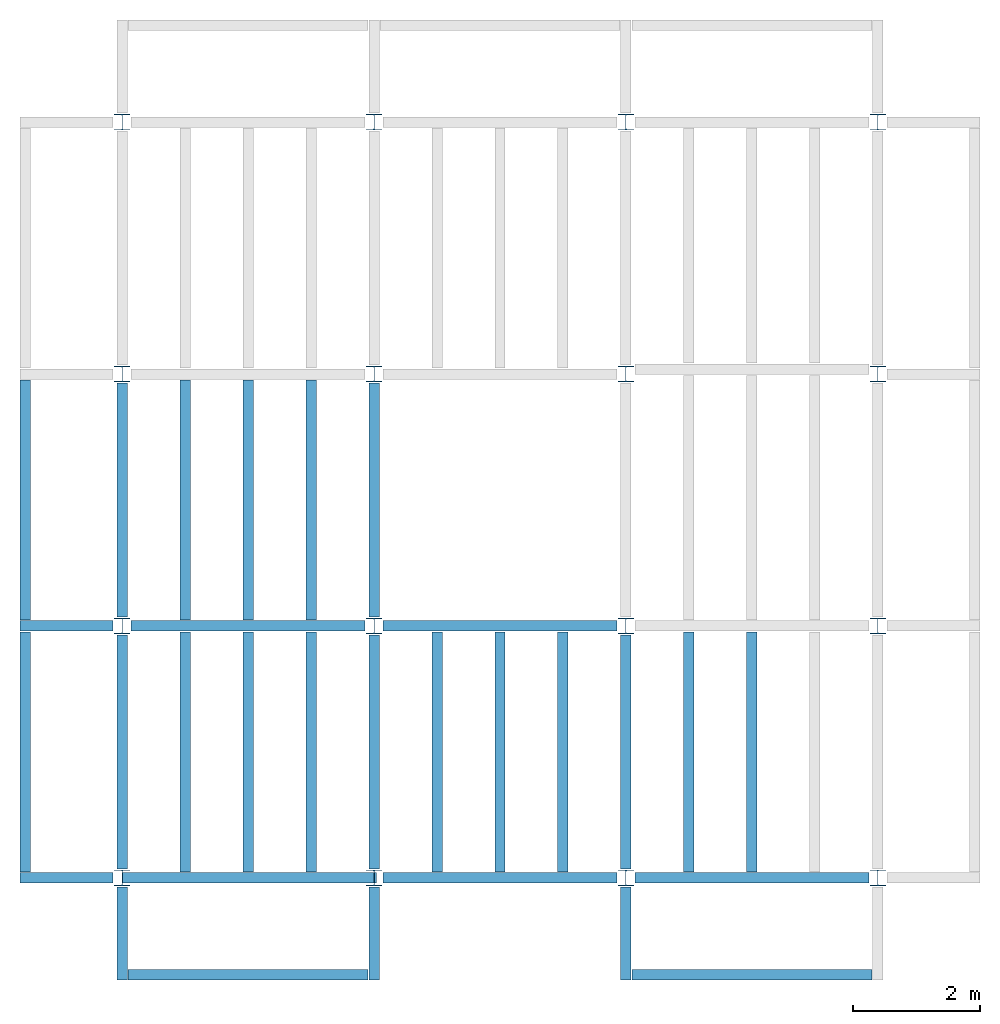
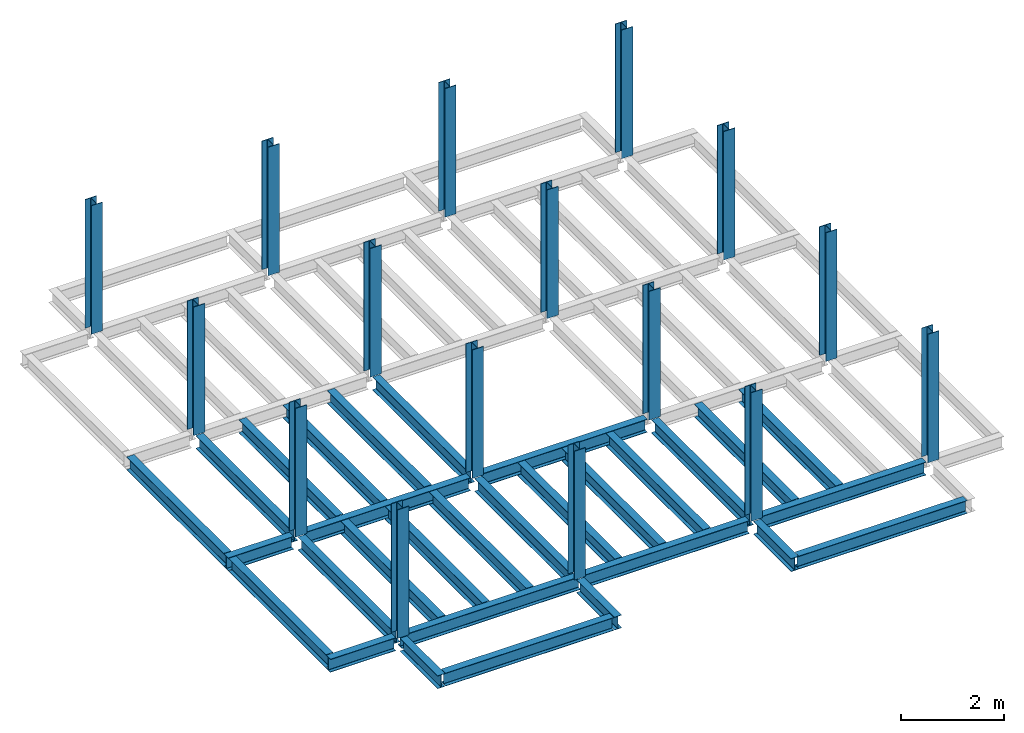
# One storey, part 1 of 3: 30 beams, 16 columns, 4 elements without a shape of their own.
"""IFC4 building model written with IfcOpenShell, lengths in feet."""

from ifc_helpers import new_model, entity, si_unit, converted_unit, derived_unit, direction, frame, origin, origin_2d, place, context, subcontext, project, spatial, line, arc, indexed_curve, i_section, outline, extrude, source, transform, mapped, material, type_object, type_shapes, element, aggregate, save


model = new_model("IFC4")

# Units and contexts
model_context = context("Model", 3, precision=0.0001, world=origin(), true_north=direction((6.123233995736766e-17, 1.0)))
plan_context = context("Plan", 3, precision=0.0001, world=origin(), true_north=direction((6.123233995736766e-17, 1.0)))
body_context = subcontext(model_context, "Body", "Model", "MODEL_VIEW")
ifc_project = project(units=[converted_unit("LENGTHUNIT", "FOOT", entity("IfcLengthMeasure", 0.3048), si_unit("LENGTHUNIT", "METRE"), dimensions=[1, 0, 0, 0, 0, 0, 0]), converted_unit("AREAUNIT", "SQUARE FOOT", entity("IfcAreaMeasure", 0.09290304), si_unit("AREAUNIT", "SQUARE_METRE"), dimensions=[2, 0, 0, 0, 0, 0, 0]), converted_unit("PLANEANGLEUNIT", "DEGREE", entity("IfcPlaneAngleMeasure", 0.017453292519943278), si_unit("PLANEANGLEUNIT", "RADIAN"), dimensions=[0, 0, 0, 0, 0, 0, 0]), converted_unit("VOLUMEUNIT", "CUBIC FOOT", entity("IfcVolumeMeasure", 0.028316846592000004), si_unit("VOLUMEUNIT", "CUBIC_METRE"), dimensions=[3, 0, 0, 0, 0, 0, 0]), si_unit("PRESSUREUNIT", "PASCAL"), derived_unit("MASSDENSITYUNIT", [(si_unit("MASSUNIT", "GRAM", prefix="KILO"), 1), (si_unit("LENGTHUNIT", "METRE"), -3)]), derived_unit("VAPORPERMEABILITYUNIT", [(si_unit("LENGTHUNIT", "METRE"), -1), (si_unit("TIMEUNIT", "SECOND"), 1)]), derived_unit("USERDEFINED", [(si_unit("MASSUNIT", "GRAM", prefix="KILO"), 1), (si_unit("LENGTHUNIT", "METRE"), 3), (si_unit("TIMEUNIT", "SECOND"), -3), (si_unit("ELECTRICCURRENTUNIT", "AMPERE"), -2)]), derived_unit("MODULUSOFELASTICITYUNIT", [(si_unit("MASSUNIT", "GRAM", prefix="KILO"), 1), (si_unit("LENGTHUNIT", "METRE"), -1), (si_unit("TIMEUNIT", "SECOND"), -2)]), derived_unit("THERMALEXPANSIONCOEFFICIENTUNIT", [(si_unit("THERMODYNAMICTEMPERATUREUNIT", "KELVIN"), -1)]), derived_unit("SPECIFICHEATCAPACITYUNIT", [(si_unit("TIMEUNIT", "SECOND"), -2), (si_unit("THERMODYNAMICTEMPERATUREUNIT", "KELVIN"), -1), (si_unit("LENGTHUNIT", "METRE"), 2)]), derived_unit("THERMALCONDUCTANCEUNIT", [(si_unit("MASSUNIT", "GRAM", prefix="KILO"), 1), (si_unit("TIMEUNIT", "SECOND"), -3), (si_unit("THERMODYNAMICTEMPERATUREUNIT", "KELVIN"), -1), (si_unit("LENGTHUNIT", "METRE"), 1)])], contexts=[model_context, plan_context])

# Site, building, storey
site_placement = place(None, origin())
site = spatial("IfcSite", under=ifc_project, at=site_placement, CompositionType="ELEMENT")
building_placement = place(site_placement, origin())
building = spatial("IfcBuilding", under=site, at=building_placement, CompositionType="ELEMENT")
storey_placement = place(building_placement, frame((0.0, 0.0, 19.875)))
storey = spatial("IfcBuildingStorey", under=building, at=storey_placement, Name="STR 03", CompositionType="ELEMENT", Elevation=19.875)

# Columns
ifc_material = material(Name="Steel ASTM A992", Category="Metal")
column_type = type_object("IfcColumnType", Name="W10X49", PredefinedType="COLUMN", material=ifc_material)
shared_shape_1 = source(origin(), body_context, "Body", "SweptSolid", [
    extrude(outline(indexed_curve([(-0.41666666666666663, -0.4166666666666676), (0.41666666666666663, -0.4166666666666676), (0.41666666666666663, -0.3699999999999996), (0.055833333333333846, -0.3699999999999996), (0.02637055078389421, -0.35779611588277277), (0.014166666666666636, -0.32833333333333287), (0.01416666666666665, 0.32833333333333303), (0.026370550783893467, 0.3577961158827727), (0.05583333333333332, 0.3700000000000003), (0.41666666666666663, 0.3700000000000003), (0.41666666666666663, 0.4166666666666656), (-0.41666666666666663, 0.4166666666666656), (-0.41666666666666663, 0.3700000000000003), (-0.05583333333333365, 0.3700000000000003), (-0.02637055078389416, 0.3577961158827734), (-0.014166666666666685, 0.32833333333333387), (-0.014166666666666685, -0.32833333333333264), (-0.026370550783893578, -0.3577961158827721), (-0.055833333333333374, -0.3699999999999996), (-0.41666666666666663, -0.3699999999999996)], segments=[line(1, 2, 3, 4), arc(4, 5, 6), line(6, 7), arc(7, 8, 9), line(9, 10, 11, 12, 13, 14), arc(14, 15, 16), line(16, 17), arc(17, 18, 19), line(19, 20, 1)], self_intersect=False)), frame((0.0, 0.0, 19.875), z_axis=(0.0, 0.0, 1.0), x_axis=(-1.0, 0.0, 0.0)), (0.0, 0.0, 1.0), 10.0),
])
type_shapes(column_type, [shared_shape_1])
for number, where, z_axis, x_axis, name in (
    (1, (13.0, 0.0, -19.875), (0.0, 0.0, 1.0), (-1.0, 0.0, 0.0), "W10X49"),
    (2, (13.0, 13.0, -19.875), (0.0, 0.0, 1.0), (-1.0, 0.0, 0.0), "W10X49"),
    (3, (13.0, 26.0, -19.875), (0.0, 0.0, 1.0), (-1.0, 0.0, 0.0), "W10X49"),
    (4, (13.0, 39.0, -19.875), (0.0, 0.0, 1.0), (-1.0, 0.0, 0.0), "W10X49"),
    (5, (0.0, 0.0, -19.875), (0.0, 0.0, 1.0), (-1.0, 0.0, 0.0), "W10X49"),
    (6, (0.0, 13.0, -19.875), (0.0, 0.0, 1.0), (-1.0, 0.0, 0.0), "W10X49"),
    (7, (0.0, 26.0, -19.875), (0.0, 0.0, 1.0), (-1.0, 0.0, 0.0), "W10X49"),
    (8, (0.0, 39.0, -19.875), (0.0, 0.0, 1.0), (-1.0, 0.0, 0.0), "W10X49"),
    (9, (26.0, 0.0, -19.875), (0.0, 0.0, 1.0), (-1.0, 0.0, 0.0), "W10X49"),
    (10, (26.0, 13.0, -19.875), (0.0, 0.0, 1.0), (-1.0, 0.0, 0.0), "W10X49"),
    (11, (26.0, 26.0, -19.875), (0.0, 0.0, 1.0), (-1.0, 0.0, 0.0), "W10X49"),
    (12, (26.0, 39.0, -19.875), (0.0, 0.0, 1.0), (-1.0, 0.0, 0.0), "W10X49"),
    (13, (39.0, 0.0, -19.875), (0.0, 0.0, 1.0), (-1.0, 0.0, 0.0), "W10X49"),
    (14, (39.0, 13.0, -19.875), (0.0, 0.0, 1.0), (-1.0, 0.0, 0.0), "W10X49"),
    (15, (39.0, 26.0, -19.875), (0.0, 0.0, 1.0), (-1.0, 0.0, 0.0), "W10X49"),
    (16, (39.0, 39.0, -19.875), (0.0, 0.0, 1.0), (-1.0, 0.0, 0.0), "W10X49"),
):
    element("IfcColumn", number, at=place(storey_placement, frame(where, z_axis=z_axis, x_axis=x_axis)), inside=storey, type_object=column_type, material=ifc_material, Name=name, ObjectType="W Shapes-Column:W10X49", PredefinedType="COLUMN", context=body_context, shape_type="MappedRepresentation", body=[
        mapped(shared_shape_1, transform((0.0, 0.0, 0.0), scale=1.0)),
    ])

# Beams
beam_type_1 = type_object("IfcBeamType", Name="W12X26", PredefinedType="JOIST", material=ifc_material)
shared_shape_2 = source(origin(), body_context, "Body", "SweptSolid", [
    extrude(outline(indexed_curve([(-0.27041666666666714, -0.47666666666666574), (-0.27041666666666714, -0.5083333333333351), (0.2704166666666669, -0.5083333333333351), (0.2704166666666669, -0.47666666666666574), (0.03458333333333309, -0.47666666666666574), (0.016905663803669493, -0.46934433619632937), (0.009583333333333202, -0.4516666666666659), (0.0095833333333332, 0.45166666666666705), (0.01690566380366948, 0.4693443361963307), (0.03458333333333325, 0.4766666666666671), (0.2704166666666669, 0.4766666666666671), (0.2704166666666669, 0.5083333333333312), (-0.2704166666666655, 0.5083333333333312), (-0.2704166666666655, 0.4766666666666671), (-0.034583333333333514, 0.47666666666666707), (-0.016905663803669865, 0.46934433619633054), (-0.009583333333333737, 0.45166666666666694), (-0.009583333333333735, -0.4516666666666658), (-0.01690566380367013, -0.4693443361963295), (-0.03458333333333368, -0.47666666666666574)], segments=[line(1, 2, 3, 4, 5), arc(5, 6, 7), line(7, 8), arc(8, 9, 10), line(10, 11, 12, 13, 14, 15), arc(15, 16, 17), line(17, 18), arc(18, 19, 20), line(20, 1)], self_intersect=False)), frame((-6.103346456692914, 0.0, 0.0), z_axis=(-1.0, 0.0, 0.0), x_axis=(0.0, -1.0, 0.0)), (0.0, 0.0, -1.0), 12.083333333333323),
])
type_shapes(beam_type_1, [shared_shape_2])
beam_1_placement = place(storey_placement, frame((6.561679790026266, 13.0, -0.5083333333333329)))
element("IfcBeam", 17, at=beam_1_placement, inside=storey, type_object=beam_type_1, material=ifc_material, Name="W12X26", ObjectType="W Shapes:W12X26", PredefinedType="JOIST", context=body_context, shape_type="MappedRepresentation", body=[
    mapped(shared_shape_2, transform((0.0, 0.0, 0.0), scale=1.0)),
])
for number, where, z_axis, x_axis, name in (
    (18, (0.0, 6.561679790026247, -0.5083333333333329), (0.0, 0.0, 1.0), (0.0, 1.0, 0.0), "W12X26"),
    (19, (26.0, 6.561679790026162, -0.5083333333333329), (0.0, 0.0, 1.0), (0.0, 1.0, 0.0), "W12X26"),
    (20, (13.0, 6.561679790026204, -0.5083333333333329), (0.0, 0.0, 1.0), (0.0, 1.0, 0.0), "W12X26"),
):
    element("IfcBeam", number, at=place(storey_placement, frame(where, z_axis=z_axis, x_axis=x_axis)), inside=storey, type_object=beam_type_1, material=ifc_material, Name=name, ObjectType="W Shapes:W12X26", PredefinedType="JOIST", context=body_context, shape_type="MappedRepresentation", body=[
        mapped(shared_shape_2, transform((0.0, 0.0, 0.0), scale=1.0)),
    ])
beam_type_2 = type_object("IfcBeamType", Name="W12X26", PredefinedType="JOIST", material=ifc_material)
shared_shape_3 = source(origin(), body_context, "Body", "SweptSolid", [
    extrude(outline(indexed_curve([(-0.27041666666666714, -0.47666666666666574), (-0.27041666666666714, -0.5083333333333351), (0.2704166666666669, -0.5083333333333351), (0.2704166666666669, -0.47666666666666574), (0.03458333333333309, -0.47666666666666574), (0.016905663803669493, -0.46934433619632937), (0.009583333333333202, -0.4516666666666659), (0.0095833333333332, 0.45166666666666705), (0.01690566380366948, 0.4693443361963307), (0.03458333333333325, 0.4766666666666671), (0.2704166666666669, 0.4766666666666671), (0.2704166666666669, 0.5083333333333312), (-0.2704166666666655, 0.5083333333333312), (-0.2704166666666655, 0.4766666666666671), (-0.034583333333333514, 0.47666666666666707), (-0.016905663803669865, 0.46934433619633054), (-0.009583333333333737, 0.45166666666666694), (-0.009583333333333735, -0.4516666666666658), (-0.01690566380367013, -0.4693443361963295), (-0.03458333333333368, -0.47666666666666574)], segments=[line(1, 2, 3, 4, 5), arc(5, 6, 7), line(7, 8), arc(8, 9, 10), line(10, 11, 12, 13, 14, 15), arc(15, 16, 17), line(17, 18), arc(18, 19, 20), line(20, 1)], self_intersect=False)), frame((-6.226706036745409, 0.0, 0.0), z_axis=(-1.0, 0.0, 0.0), x_axis=(0.0, -1.0, 0.0)), (0.0, 0.0, -1.0), 12.08333333333333),
])
type_shapes(beam_type_2, [shared_shape_3])
for number, where, name in (
    (21, (19.68503937007876, 13.0, -0.5083333333333329), "W12X26"),
    (22, (19.68503937007874, 0.0, -0.5083333333333329), "W12X26"),
):
    element("IfcBeam", number, at=place(storey_placement, frame(where)), inside=storey, type_object=beam_type_2, material=ifc_material, Name=name, ObjectType="W Shapes:W12X26", PredefinedType="JOIST", context=body_context, shape_type="MappedRepresentation", body=[
        mapped(shared_shape_3, transform((0.0, 0.0, 0.0), scale=1.0)),
    ])
for number, where, z_axis, x_axis, name in (
    (23, (0.0, 19.68503937007874, -0.5083333333333329), (0.0, 0.0, 1.0), (0.0, 1.0, 0.0), "W12X26"),
    (24, (13.0, 19.685039370078698, -0.5083333333333329), (0.0, 0.0, 1.0), (0.0, 1.0, 0.0), "W12X26"),
):
    element("IfcBeam", number, at=place(storey_placement, frame(where, z_axis=z_axis, x_axis=x_axis)), inside=storey, type_object=beam_type_2, material=ifc_material, Name=name, ObjectType="W Shapes:W12X26", PredefinedType="JOIST", context=body_context, shape_type="MappedRepresentation", body=[
        mapped(shared_shape_3, transform((0.0, 0.0, 0.0), scale=1.0)),
    ])

# Assembly, beams
assembly_1_placement = place(storey_placement, origin())
assembly_1 = element("IfcElementAssembly", 25, at=assembly_1_placement, inside=storey, Name="Structural Framing System", ObjectType="Structural Beam System:Structural Framing System", AssemblyPlace="NOTDEFINED", PredefinedType="BEAM_GRID")
beam_type_3 = type_object("IfcBeamType", Name="W12X26", PredefinedType="JOIST", material=ifc_material)
shared_shape_4 = source(origin(), body_context, "Body", "SweptSolid", [
    extrude(outline(indexed_curve([(-0.27041666666666714, -0.47666666666666574), (-0.27041666666666714, -0.5083333333333351), (0.2704166666666669, -0.5083333333333351), (0.2704166666666669, -0.47666666666666574), (0.03458333333333309, -0.47666666666666574), (0.016905663803669493, -0.46934433619632937), (0.009583333333333202, -0.4516666666666659), (0.0095833333333332, 0.45166666666666705), (0.01690566380366948, 0.4693443361963307), (0.03458333333333325, 0.4766666666666671), (0.2704166666666669, 0.4766666666666671), (0.2704166666666669, 0.5083333333333312), (-0.2704166666666655, 0.5083333333333312), (-0.2704166666666655, 0.4766666666666671), (-0.034583333333333514, 0.47666666666666707), (-0.016905663803669865, 0.46934433619633054), (-0.009583333333333737, 0.45166666666666694), (-0.009583333333333735, -0.4516666666666658), (-0.01690566380367013, -0.4693443361963295), (-0.03458333333333368, -0.47666666666666574)], segments=[line(1, 2, 3, 4, 5), arc(5, 6, 7), line(7, 8), arc(8, 9, 10), line(10, 11, 12, 13, 14, 15), arc(15, 16, 17), line(17, 18), arc(18, 19, 20), line(20, 1)], self_intersect=False)), frame((-6.187916666666566, 0.0, 0.0), z_axis=(-1.0, 0.0, 0.0), x_axis=(0.0, -1.0, 0.0)), (0.0, 0.0, -1.0), 12.375833333333075),
])
type_shapes(beam_type_3, [shared_shape_4])
beam_2_placement = place(assembly_1_placement, frame((3.2500000000000577, 6.499999999999844, -0.5083333333333329), z_axis=(0.0, 0.0, 1.0), x_axis=(0.0, 1.0, 0.0)))
beam_2 = element("IfcBeam", 26, at=beam_2_placement, type_object=beam_type_3, material=ifc_material, Name="W12X26", ObjectType="W Shapes:W12X26", PredefinedType="JOIST", context=body_context, shape_type="MappedRepresentation", body=[
    mapped(shared_shape_4, transform((0.0, 0.0, 0.0), scale=1.0)),
])
beam_3_placement = place(assembly_1_placement, frame((6.500000000000107, 6.4999999999998455, -0.5083333333333329), z_axis=(0.0, 0.0, 1.0), x_axis=(0.0, 1.0, 0.0)))
beam_3 = element("IfcBeam", 27, at=beam_3_placement, type_object=beam_type_3, material=ifc_material, Name="W12X26", ObjectType="W Shapes:W12X26", PredefinedType="JOIST", context=body_context, shape_type="MappedRepresentation", body=[
    mapped(shared_shape_4, transform((0.0, 0.0, 0.0), scale=1.0)),
])
beam_4_placement = place(assembly_1_placement, frame((9.750000000000155, 6.499999999999844, -0.5083333333333329), z_axis=(0.0, 0.0, 1.0), x_axis=(0.0, 1.0, 0.0)))
beam_4 = element("IfcBeam", 28, at=beam_4_placement, type_object=beam_type_3, material=ifc_material, Name="W12X26", ObjectType="W Shapes:W12X26", PredefinedType="JOIST", context=body_context, shape_type="MappedRepresentation", body=[
    mapped(shared_shape_4, transform((0.0, 0.0, 0.0), scale=1.0)),
])
aggregate(assembly_1, [beam_2, beam_3, beam_4])

assembly_2_placement = place(storey_placement, origin())
assembly_2 = element("IfcElementAssembly", 29, at=assembly_2_placement, inside=storey, Name="Structural Framing System", ObjectType="Structural Beam System:Structural Framing System", AssemblyPlace="NOTDEFINED", PredefinedType="BEAM_GRID")
beam_5_placement = place(assembly_2_placement, frame((3.2500000000000515, 19.49999999999968, -0.5083333333333329), z_axis=(0.0, 0.0, 1.0), x_axis=(0.0, 1.0, 0.0)))
beam_5 = element("IfcBeam", 30, at=beam_5_placement, type_object=beam_type_3, material=ifc_material, Name="W12X26", ObjectType="W Shapes:W12X26", PredefinedType="JOIST", context=body_context, shape_type="MappedRepresentation", body=[
    mapped(shared_shape_4, transform((0.0, 0.0, 0.0), scale=1.0)),
])
beam_6_placement = place(assembly_2_placement, frame((6.500000000000073, 19.499999999999666, -0.5083333333333329), z_axis=(0.0, 0.0, 1.0), x_axis=(0.0, 1.0, 0.0)))
beam_6 = element("IfcBeam", 31, at=beam_6_placement, type_object=beam_type_3, material=ifc_material, Name="W12X26", ObjectType="W Shapes:W12X26", PredefinedType="JOIST", context=body_context, shape_type="MappedRepresentation", body=[
    mapped(shared_shape_4, transform((0.0, 0.0, 0.0), scale=1.0)),
])
beam_7_placement = place(assembly_2_placement, frame((9.750000000000094, 19.49999999999966, -0.5083333333333329), z_axis=(0.0, 0.0, 1.0), x_axis=(0.0, 1.0, 0.0)))
beam_7 = element("IfcBeam", 32, at=beam_7_placement, type_object=beam_type_3, material=ifc_material, Name="W12X26", ObjectType="W Shapes:W12X26", PredefinedType="JOIST", context=body_context, shape_type="MappedRepresentation", body=[
    mapped(shared_shape_4, transform((0.0, 0.0, 0.0), scale=1.0)),
])
aggregate(assembly_2, [beam_5, beam_6, beam_7])

assembly_3_placement = place(storey_placement, origin())
assembly_3 = element("IfcElementAssembly", 33, at=assembly_3_placement, inside=storey, Name="Structural Framing System", ObjectType="Structural Beam System:Structural Framing System", AssemblyPlace="NOTDEFINED", PredefinedType="BEAM_GRID")
beam_8_placement = place(assembly_3_placement, frame((16.25000000000017, 6.499999999999801, -0.5083333333333329), z_axis=(0.0, 0.0, 1.0), x_axis=(0.0, 1.0, 0.0)))
beam_8 = element("IfcBeam", 34, at=beam_8_placement, type_object=beam_type_3, material=ifc_material, Name="W12X26", ObjectType="W Shapes:W12X26", PredefinedType="JOIST", context=body_context, shape_type="MappedRepresentation", body=[
    mapped(shared_shape_4, transform((0.0, 0.0, 0.0), scale=1.0)),
])
beam_9_placement = place(assembly_3_placement, frame((19.50000000000015, 6.499999999999801, -0.5083333333333329), z_axis=(0.0, 0.0, 1.0), x_axis=(0.0, 1.0, 0.0)))
beam_9 = element("IfcBeam", 35, at=beam_9_placement, type_object=beam_type_3, material=ifc_material, Name="W12X26", ObjectType="W Shapes:W12X26", PredefinedType="JOIST", context=body_context, shape_type="MappedRepresentation", body=[
    mapped(shared_shape_4, transform((0.0, 0.0, 0.0), scale=1.0)),
])
beam_10_placement = place(assembly_3_placement, frame((22.750000000000128, 6.499999999999801, -0.5083333333333329), z_axis=(0.0, 0.0, 1.0), x_axis=(0.0, 1.0, 0.0)))
beam_10 = element("IfcBeam", 36, at=beam_10_placement, type_object=beam_type_3, material=ifc_material, Name="W12X26", ObjectType="W Shapes:W12X26", PredefinedType="JOIST", context=body_context, shape_type="MappedRepresentation", body=[
    mapped(shared_shape_4, transform((0.0, 0.0, 0.0), scale=1.0)),
])
aggregate(assembly_3, [beam_8, beam_9, beam_10])

assembly_4_placement = place(storey_placement, origin())
assembly_4 = element("IfcElementAssembly", 37, at=assembly_4_placement, inside=storey, Name="Structural Framing System", ObjectType="Structural Beam System:Structural Framing System", AssemblyPlace="NOTDEFINED", PredefinedType="BEAM_GRID")
beam_11_placement = place(assembly_4_placement, frame((29.2500000000001, 6.49999999999975, -0.5083333333333329), z_axis=(0.0, 0.0, 1.0), x_axis=(0.0, 1.0, 0.0)))
beam_11 = element("IfcBeam", 38, at=beam_11_placement, type_object=beam_type_3, material=ifc_material, Name="W12X26", ObjectType="W Shapes:W12X26", PredefinedType="JOIST", context=body_context, shape_type="MappedRepresentation", body=[
    mapped(shared_shape_4, transform((0.0, 0.0, 0.0), scale=1.0)),
])
beam_12_placement = place(assembly_4_placement, frame((32.5000000000001, 6.499999999999737, -0.5083333333333329), z_axis=(0.0, 0.0, 1.0), x_axis=(0.0, 1.0, 0.0)))
beam_12 = element("IfcBeam", 39, at=beam_12_placement, type_object=beam_type_3, material=ifc_material, Name="W12X26", ObjectType="W Shapes:W12X26", PredefinedType="JOIST", context=body_context, shape_type="MappedRepresentation", body=[
    mapped(shared_shape_4, transform((0.0, 0.0, 0.0), scale=1.0)),
])
aggregate(assembly_4, [beam_11, beam_12])

# Beams
for number, where, z_axis, x_axis, name in (
    (40, (-5.0, 6.499999999999858, -0.5083333333314926), (0.0, 0.0, 1.0), (0.0, -1.0, 0.0), "W12X26"),
    (41, (-5.0, 19.499999999999705, -0.5083333333314926), (0.0, 0.0, 1.0), (0.0, 1.0, 0.0), "W12X26"),
):
    element("IfcBeam", number, at=place(storey_placement, frame(where, z_axis=z_axis, x_axis=x_axis)), inside=storey, type_object=beam_type_3, material=ifc_material, Name=name, ObjectType="W Shapes:W12X26", PredefinedType="JOIST", context=body_context, shape_type="MappedRepresentation", body=[
        mapped(shared_shape_4, transform((0.0, 0.0, 0.0), scale=1.0)),
    ])
beam_type_4 = type_object("IfcBeamType", Name="W12X26", PredefinedType="JOIST", material=ifc_material)
shared_shape_5 = source(origin(), body_context, "Body", "SweptSolid", [
    extrude(outline(indexed_curve([(-0.27041666666666714, -0.47666666666666574), (-0.27041666666666714, -0.5083333333333351), (0.2704166666666669, -0.5083333333333351), (0.2704166666666669, -0.47666666666666574), (0.03458333333333309, -0.47666666666666574), (0.016905663803669493, -0.46934433619632937), (0.009583333333333202, -0.4516666666666659), (0.0095833333333332, 0.45166666666666705), (0.01690566380366948, 0.4693443361963307), (0.03458333333333325, 0.4766666666666671), (0.2704166666666669, 0.4766666666666671), (0.2704166666666669, 0.5083333333333312), (-0.2704166666666655, 0.5083333333333312), (-0.2704166666666655, 0.4766666666666671), (-0.034583333333333514, 0.47666666666666707), (-0.016905663803669865, 0.46934433619633054), (-0.009583333333333737, 0.45166666666666694), (-0.009583333333333735, -0.4516666666666658), (-0.01690566380367013, -0.4693443361963295), (-0.03458333333333368, -0.47666666666666574)], segments=[line(1, 2, 3, 4, 5), arc(5, 6, 7), line(7, 8), arc(8, 9, 10), line(10, 11, 12, 13, 14, 15), arc(15, 16, 17), line(17, 18), arc(18, 19, 20), line(20, 1)], self_intersect=False)), frame((-6.165026246719308, 0.0, 0.0), z_axis=(-1.0, 0.0, 0.0), x_axis=(0.0, -1.0, 0.0)), (0.0, 0.0, -1.0), 12.08333333333334),
])
type_shapes(beam_type_4, [shared_shape_5])
beam_13_placement = place(storey_placement, frame((32.623359580052536, 0.0, -0.5083333333333329)))
element("IfcBeam", 42, at=beam_13_placement, inside=storey, type_object=beam_type_4, material=ifc_material, Name="W12X26", ObjectType="W Shapes:W12X26", PredefinedType="JOIST", context=body_context, shape_type="MappedRepresentation", body=[
    mapped(shared_shape_5, transform((0.0, 0.0, 0.0), scale=1.0)),
])
beam_type_5 = type_object("IfcBeamType", Name="W12X26", PredefinedType="JOIST", material=ifc_material)
shared_shape_6 = source(origin(), body_context, "Body", "SweptSolid", [
    extrude(outline(indexed_curve([(0.47666666666666574, -0.2704166666666672), (0.5083333333333351, -0.2704166666666672), (0.5083333333333351, 0.27041666666666686), (0.47666666666666574, 0.27041666666666686), (0.47666666666666574, 0.03458333333333307), (0.46934433619632937, 0.016905663803669473), (0.4516666666666659, 0.00958333333333318), (-0.45166666666666705, 0.00958333333333318), (-0.4693443361963307, 0.01690566380366946), (-0.4766666666666671, 0.03458333333333323), (-0.4766666666666671, 0.27041666666666686), (-0.5083333333333312, 0.27041666666666686), (-0.5083333333333312, -0.27041666666666553), (-0.4766666666666671, -0.27041666666666553), (-0.47666666666666707, -0.034583333333333535), (-0.46934433619633054, -0.016905663803669885), (-0.45166666666666694, -0.00958333333333376), (0.4516666666666658, -0.009583333333333756), (0.4693443361963295, -0.01690566380367015), (0.47666666666666574, -0.0345833333333337)], segments=[line(1, 2, 3, 4, 5), arc(5, 6, 7), line(7, 8), arc(8, 9, 10), line(10, 11, 12, 13, 14, 15), arc(15, 16, 17), line(17, 18), arc(18, 19, 20), line(20, 1)], self_intersect=False)), frame((-2.0416666666666208, 0.0, 0.0), z_axis=(1.0, 0.0, 0.0), x_axis=(0.0, 0.0, -1.0)), (0.0, 0.0, 1.0), 4.812083333333336),
])
type_shapes(beam_type_5, [shared_shape_6])
for number, where, z_axis, x_axis, name in (
    (43, (26.0, -2.500000000000538, -0.5083333333314926), (0.0, 0.0, 1.0), (0.0, -1.0, 0.0), "W12X26"),
    (44, (-2.499999999999853, 13.0, -0.5083333333314926), (0.0, 0.0, 1.0), (-1.0, 0.0, 0.0), "W12X26"),
    (45, (-2.4999999999998743, 0.0, -0.5083333333314926), (0.0, 0.0, 1.0), (-1.0, 0.0, 0.0), "W12X26"),
):
    element("IfcBeam", number, at=place(storey_placement, frame(where, z_axis=z_axis, x_axis=x_axis)), inside=storey, type_object=beam_type_5, material=ifc_material, Name=name, ObjectType="W Shapes:W12X26", PredefinedType="JOIST", context=body_context, shape_type="MappedRepresentation", body=[
        mapped(shared_shape_6, transform((0.0, 0.0, 0.0), scale=1.0)),
    ])
beam_type_6 = type_object("IfcBeamType", Name="W12X26", PredefinedType="JOIST", material=ifc_material)
shared_shape_7 = source(origin(), body_context, "Body", "SweptSolid", [
    extrude(outline(indexed_curve([(0.47666666666666574, -0.2704166666666672), (0.5083333333333351, -0.2704166666666672), (0.5083333333333351, 0.27041666666666686), (0.47666666666666574, 0.27041666666666686), (0.47666666666666574, 0.03458333333333307), (0.46934433619632937, 0.016905663803669473), (0.4516666666666659, 0.00958333333333318), (-0.45166666666666705, 0.00958333333333318), (-0.4693443361963307, 0.01690566380366946), (-0.4766666666666671, 0.03458333333333323), (-0.4766666666666671, 0.27041666666666686), (-0.5083333333333312, 0.27041666666666686), (-0.5083333333333312, -0.27041666666666553), (-0.4766666666666671, -0.27041666666666553), (-0.47666666666666707, -0.034583333333333535), (-0.46934433619633054, -0.016905663803669885), (-0.45166666666666694, -0.00958333333333376), (0.4516666666666658, -0.009583333333333756), (0.4693443361963295, -0.01690566380367015), (0.47666666666666574, -0.0345833333333337)], segments=[line(1, 2, 3, 4, 5), arc(5, 6, 7), line(7, 8), arc(8, 9, 10), line(10, 11, 12, 13, 14, 15), arc(15, 16, 17), line(17, 18), arc(18, 19, 20), line(20, 1)], self_intersect=False)), frame((-6.187916666666685, 0.0, 0.0), z_axis=(1.0, 0.0, 0.0), x_axis=(0.0, 0.0, -1.0)), (0.0, 0.0, 1.0), 12.375833333333318),
])
type_shapes(beam_type_6, [shared_shape_7])
beam_14_placement = place(storey_placement, frame((32.50000000000002, -5.0, -0.5083333333314926)))
element("IfcBeam", 46, at=beam_14_placement, inside=storey, type_object=beam_type_6, material=ifc_material, Name="W Shapes:W12X26", ObjectType="W Shapes:W12X26", PredefinedType="JOIST", context=body_context, shape_type="MappedRepresentation", body=[
    mapped(shared_shape_7, transform((0.0, 0.0, 0.0), scale=1.0)),
])
beam_type_7 = type_object("IfcBeamType", Name="W12X26", PredefinedType="JOIST", material=ifc_material)
shared_shape_8 = source(origin(), body_context, "Body", "SweptSolid", [
    extrude(outline(indexed_curve([(-0.2704166666666641, -0.5083333333333258), (0.27041666666666764, -0.5083333333333258), (0.27041666666666764, -0.476666666666663), (0.03458333333333563, -0.47666666666665947), (0.016905663803672866, -0.46934433619632543), (0.009583333333335275, -0.4516666666666609), (0.009583333333337052, 0.45166666666667155), (0.016905663803672866, 0.46934433619633253), (0.03458333333333563, 0.4766666666666701), (0.2704166666666694, 0.4766666666666701), (0.27041666666666764, 0.50833333333334), (-0.27041666666666586, 0.50833333333334), (-0.27041666666666586, 0.4766666666666701), (-0.03458333333333208, 0.4766666666666701), (-0.016905663803667537, 0.4693443361963361), (-0.009583333333331723, 0.45166666666667155), (-0.009583333333333499, -0.4516666666666609), (-0.016905663803669313, -0.4693443361963219), (-0.03458333333333208, -0.476666666666663), (-0.27041666666666586, -0.476666666666663)], segments=[line(1, 2, 3, 4), arc(4, 5, 6), line(6, 7), arc(7, 8, 9), line(9, 10, 11, 12, 13, 14), arc(14, 15, 16), line(16, 17), arc(17, 18, 19), line(19, 20, 1)], self_intersect=False)), frame((13.0, -0.45833333333387627, 19.366666666668497), z_axis=(0.0, -1.0, 0.0), x_axis=(-1.0, 0.0, 0.0)), (0.0, 0.0, 1.0), 4.812083333333337),
])
type_shapes(beam_type_7, [shared_shape_8])
beam_15_placement = place(storey_placement, frame((0.0, 0.0, -19.875)))
element("IfcBeam", 47, at=beam_15_placement, inside=storey, type_object=beam_type_7, material=ifc_material, Name="W12X26", ObjectType="W Shapes:W12X26", PredefinedType="JOIST", context=body_context, shape_type="MappedRepresentation", body=[
    mapped(shared_shape_8, transform((0.0, 0.0, 0.0), scale=1.0)),
])
beam_type_8 = type_object("IfcBeamType", Name="W12X26", PredefinedType="JOIST", material=ifc_material)
shared_shape_9 = source(origin(), body_context, "Body", "SweptSolid", [
    extrude(outline(indexed_curve([(-0.5083333333333258, -0.270416666666665), (-0.476666666666663, -0.270416666666665), (-0.47666666666665947, -0.034583333333333854), (-0.46934433619632543, -0.016905663803669313), (-0.4516666666666609, -0.009583333333333499), (0.45166666666667155, -0.009583333333333499), (0.4693443361963361, -0.016905663803669313), (0.4766666666666701, -0.034583333333332966), (0.4766666666666701, -0.27041666666666675), (0.50833333333334, -0.27041666666666675), (0.50833333333334, 0.27041666666666675), (0.4766666666666701, 0.27041666666666764), (0.4766666666666701, 0.034583333333333854), (0.4693443361963361, 0.016905663803669313), (0.45166666666667155, 0.009583333333333499), (-0.4516666666666609, 0.009583333333333499), (-0.46934433619632543, 0.016905663803669313), (-0.476666666666663, 0.034583333333332966), (-0.476666666666663, 0.27041666666666675), (-0.5083333333333258, 0.27041666666666764)], segments=[line(1, 2, 3), arc(3, 4, 5), line(5, 6), arc(6, 7, 8), line(8, 9, 10, 11, 12, 13), arc(13, 14, 15), line(15, 16), arc(16, 17, 18), line(18, 19, 20, 1)], self_intersect=False)), frame((0.3120833333333186, -5.0, 19.366666666668497), z_axis=(1.0, 0.0, 0.0), x_axis=(0.0, 0.0, -1.0)), (0.0, 0.0, 1.0), 12.37583333333332),
])
type_shapes(beam_type_8, [shared_shape_9])
beam_16_placement = place(storey_placement, frame((0.0, 0.0, -19.875)))
element("IfcBeam", 48, at=beam_16_placement, inside=storey, type_object=beam_type_8, material=ifc_material, Name="W Shapes:W12X26", ObjectType="W Shapes:W12X26", PredefinedType="JOIST", context=body_context, shape_type="MappedRepresentation", body=[
    mapped(shared_shape_9, transform((0.0, 0.0, 0.0), scale=1.0)),
])
beam_type_9 = type_object("IfcBeamType", Name="W12X26", PredefinedType="JOIST", material=ifc_material)
shared_shape_10 = source(origin(), body_context, "Body", "SweptSolid", [
    extrude(outline(indexed_curve([(-0.27041666666666686, -0.5083333333333258), (0.27041666666666553, -0.5083333333333258), (0.27041666666666553, -0.476666666666663), (0.034583333333333535, -0.47666666666665947), (0.01690566380366997, -0.46934433619632543), (0.009583333333333712, -0.4516666666666609), (0.009583333333333974, 0.45166666666667155), (0.016905663803669285, 0.4693443361963361), (0.0345833333333337, 0.4766666666666701), (0.2704166666666672, 0.4766666666666701), (0.2704166666666672, 0.50833333333334), (-0.27041666666666686, 0.50833333333334), (-0.27041666666666686, 0.4766666666666701), (-0.03458333333333309, 0.4766666666666701), (-0.016905663803668643, 0.4693443361963361), (-0.009583333333333175, 0.45166666666667155), (-0.009583333333333433, -0.4516666666666609), (-0.01690566380366867, -0.46934433619632543), (-0.0345833333333332, -0.476666666666663), (-0.27041666666666686, -0.476666666666663)], segments=[line(1, 2, 3, 4), arc(4, 5, 6), line(6, 7), arc(7, 8, 9), line(9, 10, 11, 12, 13, 14), arc(14, 15, 16), line(16, 17), arc(17, 18, 19), line(19, 20, 1)], self_intersect=False)), frame((0.0, -0.45833333333383364, 19.366666666668497), z_axis=(0.0, -1.0, 0.0), x_axis=(-1.0, 0.0, 0.0)), (0.0, 0.0, 1.0), 4.812083333333337),
])
type_shapes(beam_type_9, [shared_shape_10])
beam_17_placement = place(storey_placement, frame((0.0, 0.0, -19.875)))
element("IfcBeam", 49, at=beam_17_placement, inside=storey, type_object=beam_type_9, material=ifc_material, Name="W12X26", ObjectType="W Shapes:W12X26", PredefinedType="JOIST", context=body_context, shape_type="MappedRepresentation", body=[
    mapped(shared_shape_10, transform((0.0, 0.0, 0.0), scale=1.0)),
])
beam_type_10 = type_object("IfcBeamType", Name="W12X26", PredefinedType="BEAM")
beam_18_placement = place(storey_placement, frame((0.0, 0.0, -0.5083333333333329), z_axis=(-1.0, 0.0, 0.0), x_axis=(0.0, -1.0, 0.0)))
element("IfcBeam", 50, at=beam_18_placement, inside=storey, type_object=beam_type_10, material=ifc_material, Name="W12X26", ObjectType="W12X26", context=model_context, shape_type="SweptSolid", body=[
    extrude(i_section(OverallWidth=0.5408333333333333, OverallDepth=1.0166666666666666, WebThickness=0.019166666666666665, FlangeThickness=0.03166666666666666, FilletRadius=0.024999999999999998, at=origin_2d()), origin(), (0.0, 0.0, -1.0), 13.123359580052494),
])

save(model, "model.ifc")
